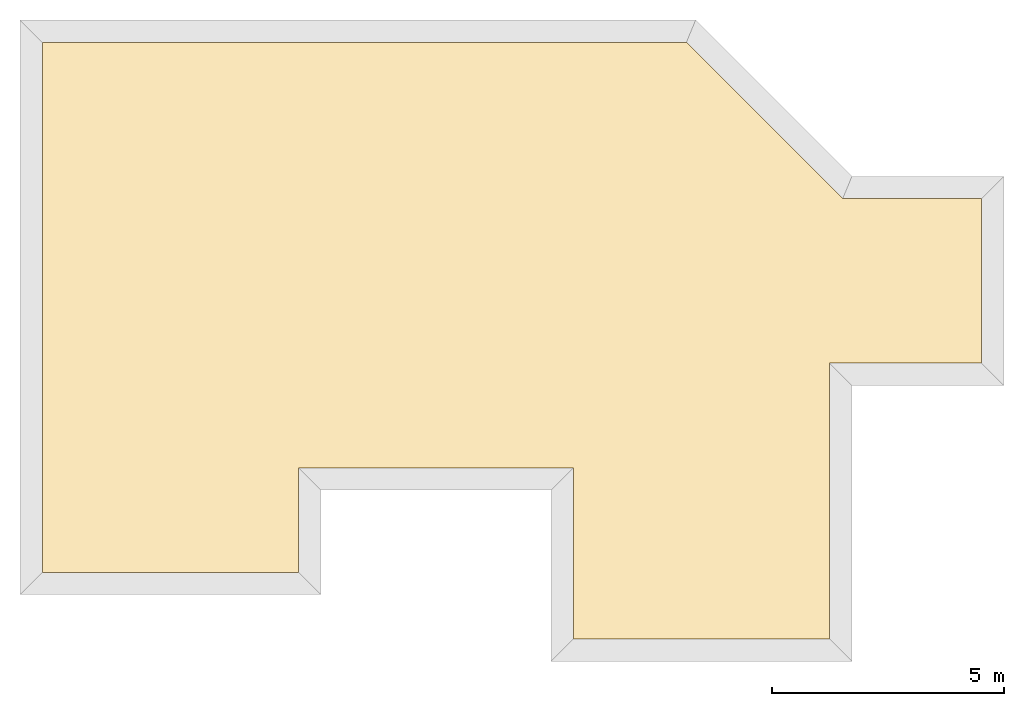
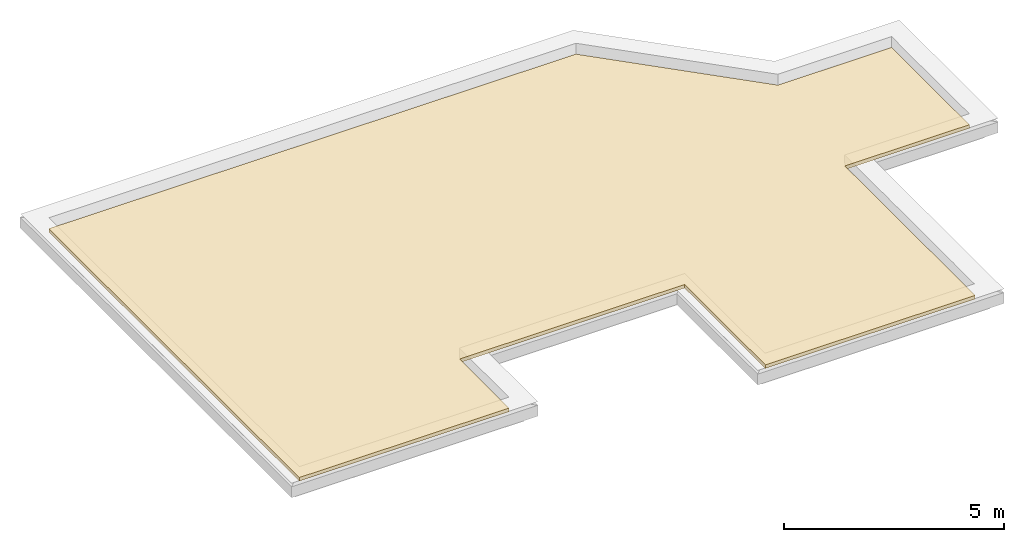
# One storey, part 2 of 3: 3 coverings.
"""IFC4 building model written with IfcOpenShell, lengths in millimetres."""

from ifc_helpers import new_model, entity, si_unit, converted_unit, frame, origin_with_axes, origin_2d_with_axis, place, context, subcontext, project, spatial, indexed_curve, outline, extrude, material, layer, layer_set, layer_usage, type_object, element, save


model = new_model("IFC4")

# Units and contexts
model_context = context("Model", 3, precision=1e-05, world=origin_with_axes())
plan_context = context("Plan", 2, precision=1e-05, world=origin_2d_with_axis())
body_context = subcontext(model_context, "Body", "Model", "MODEL_VIEW")
ifc_project = project(units=[si_unit("VOLUMEUNIT", "CUBIC_METRE"), si_unit("LENGTHUNIT", "METRE", prefix="MILLI"), converted_unit("PLANEANGLEUNIT", "degree", entity("IfcReal", 0.0174532925199433), si_unit("PLANEANGLEUNIT", "RADIAN"), dimensions=[0, 0, 0, 0, 0, 0, 0]), si_unit("AREAUNIT", "SQUARE_METRE")], contexts=[model_context, plan_context])

# Site, building, storey
site_placement = place(None, origin_with_axes())
site = spatial("IfcSite", under=ifc_project, at=site_placement)
building_placement = place(site_placement, origin_with_axes())
building = spatial("IfcBuilding", under=site, at=building_placement, Name="Building")
storey_placement = place(building_placement, frame((0.0, 0.0, 2894.99998092651), z_axis=(0.0, 0.0, 1.0), x_axis=(1.0, 0.0, 0.0)))
storey = spatial("IfcBuildingStorey", under=building, at=storey_placement, Name="Dach")

# Coverings
ifc_material = material(Name="XPS")
ifc_layer = layer(ifc_material, 100.0)
ifc_layer_set = layer_set([ifc_layer])
ifc_layer_usage_1 = layer_usage(ifc_layer_set, "AXIS3", "POSITIVE", 0.0)
covering_type = type_object("IfcCoveringType", Name="XPS 10cm", PredefinedType="INSULATION", material=ifc_layer_set)
covering_1_placement = place(storey_placement, frame((2967.39172935486, 5382.35664367676, 200.000047683719), z_axis=(0.0, 0.0, 1.0), x_axis=(1.0, 0.0, 0.0)))
element("IfcCovering", 1, at=covering_1_placement, inside=storey, type_object=covering_type, material=ifc_layer_usage_1, Name="Covering", context=body_context, shape_type="SweptSolid", body=[
    extrude(outline(indexed_curve([(8704.86328125, -3284.29907226562), (8704.8642578125, -6964.2978515625), (14216.013671875, -6964.2958984375), (14216.01171875, -1034.2978515625), (17486.013671875, -1034.296875), (17486.013671875, 2505.70190429688), (14497.189453125, 2505.70092773438), (11135.248046875, 5867.63916015625), (-2717.392578125, 5867.64453125), (-2717.39208984375, -5532.35595703125), (2793.7373046875, -5532.35595703125), (2793.7373046875, -3284.3017578125), (8704.86328125, -3284.29907226562)])), None, (0.0, 0.0, 1.0), 100.0),
])
ifc_layer_usage_2 = layer_usage(ifc_layer_set, "AXIS3", "POSITIVE", 0.0)
covering_2_placement = place(storey_placement, frame((2967.39172935486, 5382.35664367676, 200.000047683719), z_axis=(0.0, 0.0, 1.0), x_axis=(1.0, 0.0, 0.0)))
element("IfcCovering", 2, at=covering_2_placement, inside=storey, type_object=covering_type, material=ifc_layer_usage_2, Name="Covering", context=body_context, shape_type="SweptSolid", body=[
    extrude(outline(indexed_curve([(8704.86328125, -3284.29907226562), (8704.8642578125, -6964.2978515625), (14216.013671875, -6964.2958984375), (14216.01171875, -1034.2978515625), (17486.013671875, -1034.296875), (17486.013671875, 2505.70190429688), (14497.189453125, 2505.70092773438), (11135.248046875, 5867.63916015625), (-2717.392578125, 5867.64453125), (-2717.39208984375, -5532.35595703125), (2793.7373046875, -5532.35595703125), (2793.7373046875, -3284.3017578125), (8704.86328125, -3284.29907226562)])), None, (0.0, 0.0, 1.0), 100.0),
])
ifc_layer_usage_3 = layer_usage(ifc_layer_set, "AXIS3", "POSITIVE", 0.0)
covering_3_placement = place(storey_placement, frame((2967.39172935486, 5382.35664367676, 200.000047683719), z_axis=(0.0, 0.0, 1.0), x_axis=(1.0, 0.0, 0.0)))
element("IfcCovering", 3, at=covering_3_placement, inside=storey, type_object=covering_type, material=ifc_layer_usage_3, Name="Covering", context=body_context, shape_type="SweptSolid", body=[
    extrude(outline(indexed_curve([(8704.86328125, -3284.29907226562), (8704.8642578125, -6964.2978515625), (14216.013671875, -6964.2958984375), (14216.01171875, -1034.2978515625), (17486.013671875, -1034.296875), (17486.013671875, 2505.70190429688), (14497.189453125, 2505.70092773438), (11135.248046875, 5867.63916015625), (-2717.392578125, 5867.64453125), (-2717.39208984375, -5532.35595703125), (2793.7373046875, -5532.35595703125), (2793.7373046875, -3284.3017578125), (8704.86328125, -3284.29907226562)])), None, (0.0, 0.0, 1.0), 100.0),
])

save(model, "model.ifc")
